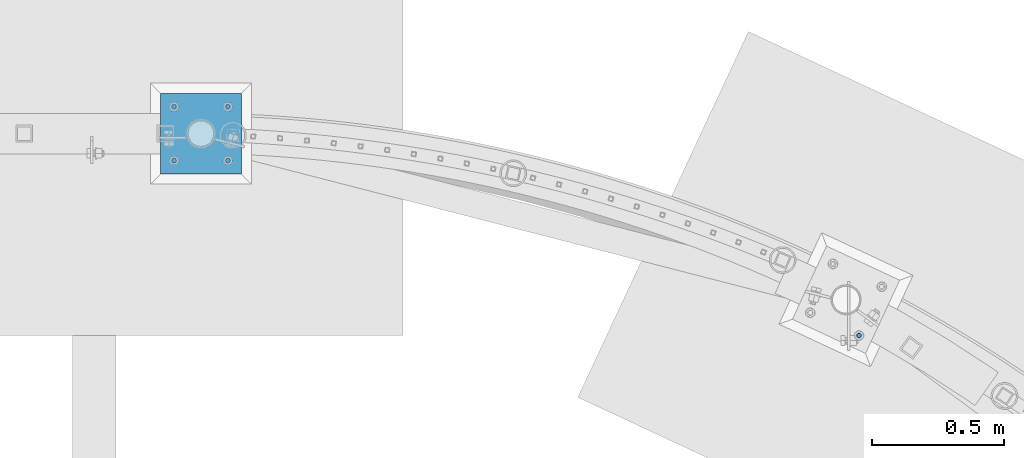
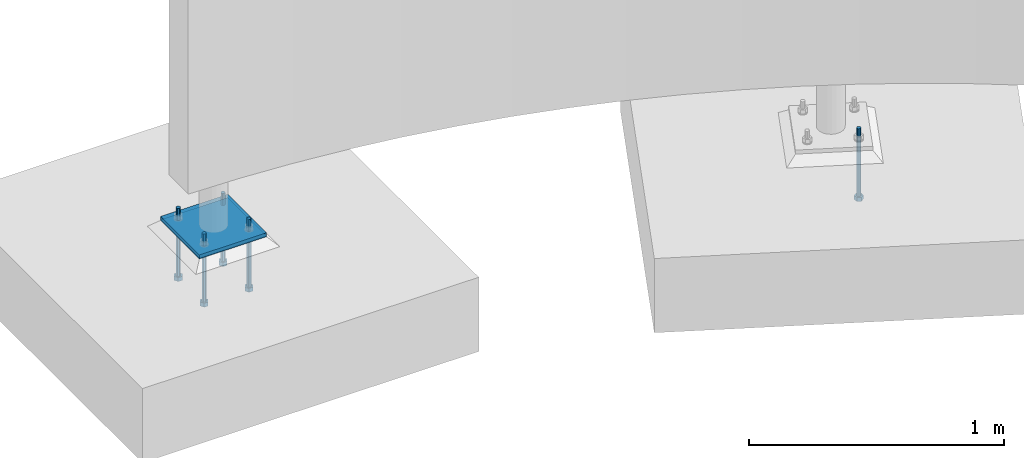
# One storey, part 449 of 975: 7 beams.
"""IFC2X3 building model written with IfcOpenShell, lengths in millimetres."""

import ifcopenshell
import ifcopenshell.guid

model = None  # the IFC model being written
_history = None  # IfcOwnerHistory: only IFC2X3 demands one
_inside = {}  # id of a spatial element -> (the spatial element, [elements in it])
_under = {}  # id of a project, library or spatial element -> (it, [spatial elements below it])
_declared = {}  # id of a project -> (the project, [libraries it declares])
_typed = {}  # id of a type object -> (the type object, [elements of that type])
_made_of = {}  # id of a material, layer set ... -> (it, [elements and type objects made of it])


def new_model(schema):
    """Start an empty IFC model of exactly this schema.

    Asked for "IFC4X3", IfcOpenShell would pick the latest addendum, in which some entities
    have other attributes; the version numbers below select the first issue.
    IFC2X3 requires an IfcOwnerHistory on every rooted entity: one is made here for all.
    """
    global model, _history
    if schema == "IFC4X3":
        model = ifcopenshell.file(schema_version=(4, 3, 0, 0))
    else:
        model = ifcopenshell.file(schema=schema)
    _inside.clear()
    _under.clear()
    _declared.clear()
    _typed.clear()
    _made_of.clear()
    _history = None
    if model.schema == "IFC2X3":
        org = make("IfcOrganization", Name="unknown")
        user = make(
            "IfcPersonAndOrganization",
            ThePerson=make("IfcPerson", FamilyName="unknown"),
            TheOrganization=org,
        )
        app = make(
            "IfcApplication",
            ApplicationDeveloper=org,
            Version="unknown",
            ApplicationFullName="unknown",
            ApplicationIdentifier="unknown",
        )
        _history = make(
            "IfcOwnerHistory",
            OwningUser=user,
            OwningApplication=app,
            ChangeAction="ADDED",
            CreationDate=0,
        )
    return model


def make(cls, **values):
    """One entity of the class cls with the attributes given. An attribute that is None is left unset."""
    return model.create_entity(
        cls, **{name: value for name, value in values.items() if value is not None}
    )


def rooted(cls, **values):
    """An entity with a GlobalId (a new one), such as an element, a storey or a relation."""
    return make(cls, GlobalId=ifcopenshell.guid.new(), OwnerHistory=_history, **values)


def si_unit(unit_type, name, prefix=None):
    """IfcSIUnit, for example si_unit("LENGTHUNIT", "METRE", prefix="MILLI")."""
    return make("IfcSIUnit", UnitType=unit_type, Prefix=prefix, Name=name)


def assignment(units):
    """IfcUnitAssignment: the units of a project."""
    return None if units is None else make("IfcUnitAssignment", Units=units)


def point(xyz):
    """IfcCartesianPoint."""
    return None if xyz is None else make("IfcCartesianPoint", Coordinates=xyz)


def direction(xyz):
    """IfcDirection."""
    return None if xyz is None else make("IfcDirection", DirectionRatios=xyz)


def frame(location, z_axis=None, x_axis=None):
    """IfcAxis2Placement3D, a coordinate frame: its origin and axes. An axis left out is left unset."""
    return make(
        "IfcAxis2Placement3D",
        Location=point(location),
        Axis=direction(z_axis),
        RefDirection=direction(x_axis),
    )


def origin_with_axes():
    """The frame at (0, 0, 0) with the z axis (0, 0, 1) and the x axis (1, 0, 0) written out."""
    return frame((0.0, 0.0, 0.0), z_axis=(0.0, 0.0, 1.0), x_axis=(1.0, 0.0, 0.0))


def place(relative_to, where):
    """IfcLocalPlacement: puts the frame where relative to a parent placement (None: the world)."""
    return make(
        "IfcLocalPlacement", PlacementRelTo=relative_to, RelativePlacement=where
    )


def context(
    kind, dimensions, precision=None, world=None, true_north=None, identifier=None
):
    """IfcGeometricRepresentationContext, for example the 3D "Model" context."""
    return make(
        "IfcGeometricRepresentationContext",
        ContextIdentifier=identifier,
        ContextType=kind,
        CoordinateSpaceDimension=dimensions,
        Precision=precision,
        WorldCoordinateSystem=world,
        TrueNorth=true_north,
    )


def subcontext(parent, identifier, kind, view, scale=None):
    """IfcGeometricRepresentationSubContext, for example "Body" below "Model"."""
    return make(
        "IfcGeometricRepresentationSubContext",
        ContextIdentifier=identifier,
        ContextType=kind,
        ParentContext=parent,
        TargetScale=scale,
        TargetView=view,
    )


def project(units=None, contexts=None):
    """IfcProject with its units and contexts."""
    return rooted(
        "IfcProject",
        Name="project",
        RepresentationContexts=contexts,
        UnitsInContext=assignment(units),
    )


def spatial(cls, under=None, at=None, **own):
    """A site, building, storey or space (cls), placed at a placement, below another one or the project."""
    s = rooted(cls, ObjectPlacement=at, **own)
    if under is not None:
        _under.setdefault(under.id(), (under, []))[1].append(s)
    return s


def faces_of(points, faces, orient=None, outer=None):
    """IfcFace entities. A face is a list of loops; a loop is a list of indices into points, from 0.

    orient and outer hold one flag for each loop. By default every Orientation is true, the
    first loop of a face is its IfcFaceOuterBound and the others are IfcFaceBound.
    """
    made = []
    for i, loops in enumerate(faces):
        bounds = []
        for j, loop in enumerate(loops):
            is_outer = j == 0 if outer is None else outer[i][j]
            bounds.append(
                make(
                    "IfcFaceOuterBound" if is_outer else "IfcFaceBound",
                    Bound=make("IfcPolyLoop", Polygon=[points[k] for k in loop]),
                    Orientation=True if orient is None else orient[i][j],
                )
            )
        made.append(make("IfcFace", Bounds=bounds))
    return made


def faceted_brep(points, faces, orient=None, outer=None, voids=None):
    """IfcFacetedBrep: a solid bounded by flat faces; with voids (closed shells), ...WithVoids."""
    shared = [point(p) for p in points]
    hull = make("IfcClosedShell", CfsFaces=faces_of(shared, faces, orient, outer))
    if voids is None:
        return make("IfcFacetedBrep", Outer=hull)
    return make(
        "IfcFacetedBrepWithVoids",
        Outer=hull,
        Voids=[
            make(cls, CfsFaces=faces_of(shared, fs, o, b)) for cls, fs, o, b in voids
        ],
    )


def shape(context_of_items, identifier, shape_type, items):
    """IfcShapeRepresentation: the items that make up one representation, for example the "Body"."""
    return make(
        "IfcShapeRepresentation",
        ContextOfItems=context_of_items,
        RepresentationIdentifier=identifier,
        RepresentationType=shape_type,
        Items=items,
    )


def material(Name=None, Category=None):
    """IfcMaterial."""
    return make("IfcMaterial", Name=Name, Category=Category)


def made_of(thing, what):
    """Note that an element or type object is made of a material, layer set ...; save() writes the relation."""
    if what is not None:
        _made_of.setdefault(what.id(), (what, []))[1].append(thing)
    return thing


def type_object(cls, material=None, **own):
    """A type object (cls), such as IfcWallType, which elements share."""
    return made_of(rooted(cls, **own), material)


def element(
    cls,
    number,
    at=None,
    inside=None,
    cuts=None,
    type_object=None,
    material=None,
    context=None,
    identifier="Body",
    shape_type=None,
    held_by="IfcProductDefinitionShape",
    body=None,
    shapes=None,
    **own,
):
    """One element of the class cls, such as IfcWall. Its Tag is "e" and its number.

    at: its placement. inside: the storey or other place that contains it. cuts: it is an
    opening in that element (IfcRelVoidsElement). A single representation is given by context,
    identifier, shape_type and body (its items); several are given by shapes. held_by: the class
    of the entity that holds the representations. save() writes the other relations.
    """
    e = rooted(cls, Tag="e%d" % number, ObjectPlacement=at, **own)
    if body is not None:
        shapes = [shape(context, identifier, shape_type, body)]
    if shapes is not None:
        e.Representation = make(held_by, Representations=shapes)
    if inside is not None:
        _inside.setdefault(inside.id(), (inside, []))[1].append(e)
    if cuts is not None:
        rooted(
            "IfcRelVoidsElement", RelatingBuildingElement=cuts, RelatedOpeningElement=e
        )
    if type_object is not None:
        _typed.setdefault(type_object.id(), (type_object, []))[1].append(e)
    return made_of(e, material)


def aggregate(whole, parts):
    """IfcRelAggregates: a whole, such as a stair, and the parts it consists of."""
    return rooted("IfcRelAggregates", RelatingObject=whole, RelatedObjects=parts)


def save(model, path):
    """Write the relations noted so far, then the file.

    IfcRelAggregates (storeys below a building ...), IfcRelContainedInSpatialStructure (elements
    in a storey), IfcRelDefinesByType, IfcRelAssociatesMaterial and IfcRelDeclares: one each for
    every whole, place, type object, material and project.
    """
    for whole, parts in _under.values():
        aggregate(whole, parts)
    for where, things in _inside.values():
        rooted(
            "IfcRelContainedInSpatialStructure",
            RelatedElements=things,
            RelatingStructure=where,
        )
    for kind, things in _typed.values():
        rooted("IfcRelDefinesByType", RelatedObjects=things, RelatingType=kind)
    for what, things in _made_of.values():
        rooted("IfcRelAssociatesMaterial", RelatedObjects=things, RelatingMaterial=what)
    for by, libraries in _declared.values():
        rooted("IfcRelDeclares", RelatingContext=by, RelatedDefinitions=libraries)
    model.write(path)


model = new_model("IFC2X3")

# Units and contexts
model_context = context("Model", 3, precision=1e-05, world=origin_with_axes())
body_context = subcontext(model_context, "Body", "Model", "MODEL_VIEW")
ifc_project = project(units=[si_unit("LENGTHUNIT", "METRE", prefix="MILLI"), si_unit("AREAUNIT", "SQUARE_METRE"), si_unit("VOLUMEUNIT", "CUBIC_METRE"), si_unit("MASSUNIT", "GRAM", prefix="KILO"), si_unit("TIMEUNIT", "SECOND"), si_unit("PLANEANGLEUNIT", "RADIAN"), si_unit("SOLIDANGLEUNIT", "STERADIAN"), si_unit("THERMODYNAMICTEMPERATUREUNIT", "DEGREE_CELSIUS"), si_unit("LUMINOUSINTENSITYUNIT", "LUMEN")], contexts=[model_context])

# Site, building, storey
site_placement = place(None, origin_with_axes())
site = spatial("IfcSite", under=ifc_project, at=site_placement, CompositionType="ELEMENT")
building_placement = place(site_placement, origin_with_axes())
building = spatial("IfcBuilding", under=site, at=building_placement, Name="Undefined", CompositionType="ELEMENT")
storey_placement = place(building_placement, origin_with_axes())
storey = spatial("IfcBuildingStorey", under=building, at=storey_placement, Name="Undefined", CompositionType="ELEMENT", Elevation=0.0)

# Beams
ifc_material_1 = material(Name="STEEL/A36")
beam_type_1 = type_object("IfcBeamType", PredefinedType="NOTDEFINED")
beam_1_placement = place(storey_placement, frame((16424.275, 29810.075, -257.175), z_axis=(-0.999999999999998, 6.90000001668524e-08, 0.0), x_axis=(0.0, 1.0, 0.0)))
element("IfcBeam", 1, at=beam_1_placement, inside=storey, type_object=beam_type_1, material=ifc_material_1, Name="PLATE", context=body_context, shape_type="Brep", body=[
    faceted_brep([(0.0, 9.52499999999964, -152.4), (0.0, 9.52499999999964, 152.4), (304.799999999152, 9.52499999999964, 152.4), (304.799999999152, 9.52499999999964, -152.4), (0.0, -9.52499999999964, 152.4), (304.799999999152, -9.52499999999964, 152.4), (0.0, -9.52499999999964, -152.4), (304.799999999152, -9.52499999999964, -152.4)], [[[0, 1, 2, 3]], [[1, 4, 5, 2]], [[4, 6, 7, 5]], [[6, 0, 3, 7]], [[5, 7, 3, 2]], [[6, 4, 1, 0]]]),
])
ifc_material_2 = material(Name="STEEL/F1554-36")
beam_type_2 = type_object("IfcBeamType", PredefinedType="NOTDEFINED")
beam_2_placement = place(storey_placement, frame((18908.6428556432, 29200.3659553737, -304.799999999999), z_axis=(0.422618261967726, 0.906307786930786, 0.0), x_axis=(0.0, 0.0, -1.0)))
element("IfcBeam", 2, at=beam_2_placement, inside=storey, type_object=beam_type_2, material=ifc_material_2, Name="HEADED_ANCHOR_BOLT", context=body_context, shape_type="Brep", body=[
    faceted_brep([(209.543749999999, -9.13000011446275, 15.8100004196049), (209.543749999999, -18.2600002288382, 4.72937244921923e-11), (228.593749999998, -18.2600002288382, 4.72937244921923e-11), (228.593749999998, -9.13000011446275, 15.8100004196049), (209.543749999999, 9.13000011438271, 15.8100004195576), (228.593749999998, 9.13000011438271, 15.8100004195576), (209.543749999999, 18.2600002288382, -4.72937244921923e-11), (228.593749999998, 18.2600002288382, -4.72937244921923e-11), (209.543749999999, 9.13000011446275, -15.8100004196049), (228.593749999998, 9.13000011446275, -15.8100004196049), (209.543749999999, -9.13000011438271, -15.8100004195576), (228.593749999998, -9.13000011438271, -15.8100004195576), (209.543749999999, -4.4776800552936, 9.29799844178979), (209.543749999999, -8.068500660469, 6.43441456491473), (209.543749999999, -10.0612557561763, 2.2964159705416), (209.543749999999, -10.0612557561617, -2.29641597048976), (209.543749999999, -8.0685006604399, -6.4344145648729), (209.543749999999, -4.47768005524995, -9.29799844176705), (209.543749999999, 2.91038304567337e-11, -10.3199996948015), (209.543749999999, 4.4776800552936, -9.29799844178979), (209.543749999999, 8.068500660469, -6.43441456491473), (209.543749999999, 10.0612557561763, -2.2964159705416), (209.543749999999, 10.0612557561617, 2.29641597048976), (209.543749999999, 8.0685006604399, 6.4344145648729), (209.543749999999, 4.47768005524995, 9.29799844176705), (209.543749999999, -2.91038304567337e-11, 10.3199996948015), (228.593749999998, -2.91038304567337e-11, 10.3199996948015), (228.593749999998, -4.4776800552936, 9.29799844178979), (228.593749999998, -8.068500660469, 6.43441456491473), (228.593749999998, -10.0612557561763, 2.2964159705416), (228.593749999998, -10.0612557561617, -2.29641597048976), (228.593749999998, -8.0685006604399, -6.4344145648729), (228.593749999998, -4.47768005524995, -9.29799844176705), (228.593749999998, 2.91038304567337e-11, -10.3199996948015), (228.593749999998, 4.4776800552936, -9.29799844178979), (228.593749999998, 8.068500660469, -6.43441456491473), (228.593749999998, 10.0612557561763, -2.2964159705416), (228.593749999998, 10.0612557561617, 2.29641597048976), (228.593749999998, 8.0685006604399, 6.4344145648729), (228.593749999998, 4.47768005524995, 9.29799844176705), (0.0, -6.73519209080223, 6.73519209080186), (0.0, -9.52499999999964, 0.0), (228.6, -9.52500000000146, 0.0), (228.6, -6.73519209080405, 6.73519209080223), (-9.87109982941227e-13, -1.20792265079217e-13, 9.52499961853027), (228.6, 0.0, 9.52499999999964), (0.0, 6.73519209080223, 6.73519209080186), (228.6, 6.73519209080405, 6.73519209080223), (0.0, 9.52499999999964, 0.0), (228.6, 9.52500000000146, 0.0), (0.0, 6.73519209080223, -6.73519209080186), (228.6, 6.73519209080405, -6.73519209080223), (2.95075507493764e-12, -1.20792265079217e-13, -9.52499961853027), (228.6, 0.0, -9.52499999999964), (-114.297914995421, -6.36396103067818, 6.36396103068091), (-114.297914995421, -2.18278728425503e-11, 8.99999999997999), (-114.297914995421, 6.36396103064908, 6.36396103064817), (-114.297914995421, 8.99999999997817, -2.27373675443232e-11), (-114.297914995421, 6.36396103067818, -6.36396103068091), (-114.297914995421, 2.18278728425503e-11, -8.99999999997999), (-114.297914995421, -6.36396103064908, -6.36396103064817), (-114.297914995421, -8.99999999997817, 2.27373675443232e-11), (0.0149743263646087, 6.36396103067818, -6.36396103067909), (0.0149743263646087, 0.0, -9.0), (0.0149743263646087, -6.36396103067818, -6.36396103067909), (0.0149743263987148, -8.9999995411581, -1.00796984270346e-06), (0.0149743263646087, -6.36396103067818, 6.36396103067909), (0.0149743263646087, 0.0, 9.0), (0.0149743263646087, 6.36396103067818, 6.36396103067909), (0.0149743263987148, 9.0000004588419, -1.00796984270346e-06), (0.0, -6.73519209080223, -6.73519209080186), (228.6, -6.73519209080405, -6.73519209080223)], [[[0, 1, 2, 3]], [[4, 0, 3, 5]], [[6, 4, 5, 7]], [[8, 6, 7, 9]], [[10, 8, 9, 11]], [[0, 4, 6, 8, 10, 1], [12, 13, 14, 15, 16, 17, 18, 19, 20, 21, 22, 23, 24, 25]], [[12, 25, 26, 27]], [[13, 12, 27, 28]], [[14, 13, 28, 29]], [[15, 14, 29, 30]], [[16, 15, 30, 31]], [[17, 16, 31, 32]], [[18, 17, 32, 33]], [[19, 18, 33, 34]], [[20, 19, 34, 35]], [[21, 20, 35, 36]], [[22, 21, 36, 37]], [[23, 22, 37, 38]], [[24, 23, 38, 39]], [[25, 24, 39, 26]], [[9, 7, 5, 3, 2, 11], [38, 37, 36, 35, 34, 33, 32, 31, 30, 29, 28, 27, 26, 39]], [[1, 10, 11, 2]], [[40, 41, 42, 43]], [[44, 40, 43, 45]], [[46, 44, 45, 47]], [[48, 46, 47, 49]], [[50, 48, 49, 51]], [[52, 50, 51, 53]], [[54, 55, 56, 57, 58, 59, 60, 61]], [[59, 58, 62, 63]], [[60, 59, 63, 64]], [[61, 60, 64, 65]], [[54, 61, 65, 66]], [[55, 54, 66, 67]], [[56, 55, 67, 68]], [[57, 56, 68, 69]], [[58, 57, 69, 62]], [[40, 44, 46, 48, 50, 52, 70, 41], [68, 67, 66, 65, 64, 63, 62, 69]], [[41, 70, 71, 42]], [[53, 51, 49, 47, 45, 43, 42, 71]], [[70, 52, 53, 71]]]),
])
beam_3_placement = place(storey_placement, frame((16525.8749984741, 30064.0749969482, -304.79470833123), z_axis=(0.0, 1.0, 0.0), x_axis=(0.0, 0.0, -1.0)))
element("IfcBeam", 3, at=beam_3_placement, inside=storey, type_object=beam_type_2, material=ifc_material_2, Name="HEADED_ANCHOR_BOLT", context=body_context, shape_type="Brep", body=[
    faceted_brep([(210.349041668767, -9.13000011445183, 15.8100004196131), (210.349041668767, -18.2600002288636, 2.5465851649642e-11), (229.399041668767, -18.2600002288636, 2.5465851649642e-11), (229.399041668767, -9.13000011445183, 15.8100004196131), (210.349041668767, 9.13000011440818, 15.8100004195894), (229.399041668767, 9.13000011440818, 15.8100004195894), (210.349041668767, 18.26000022886, -2.18278728425503e-11), (229.399041668767, 18.26000022886, -2.18278728425503e-11), (210.349041668767, 9.13000011444819, -15.8100004196076), (229.399041668767, 9.13000011444819, -15.8100004196076), (210.349041668767, -9.13000011441545, -15.8100004195876), (229.399041668767, -9.13000011441545, -15.8100004195876), (210.349041668767, -4.47768005528997, 9.29799844179615), (210.349041668767, -8.06850066047264, 6.43441456491382), (210.349041668767, -10.0612557561872, 2.2964159705316), (210.349041668767, -10.0612557561799, -2.29641597050431), (210.349041668767, -8.06850066045808, -6.43441456488472), (210.349041668767, -4.47768005526814, -9.2979984417816), (210.349041668767, 1.09139364212751e-11, -10.3199996948097), (210.349041668767, 4.47768005528997, -9.29799844179433), (210.349041668767, 8.06850066047264, -6.43441456491018), (210.349041668767, 10.0612557561799, -2.29641597052978), (210.349041668767, 10.0612557561763, 2.29641597051159), (210.349041668767, 8.06850066045808, 6.43441456489199), (210.349041668767, 4.47768005526086, 9.29799844178342), (210.349041668767, -1.09139364212751e-11, 10.3199996948151), (229.399041668767, -1.09139364212751e-11, 10.3199996948151), (229.399041668767, -4.47768005528997, 9.29799844179615), (229.399041668767, -8.06850066047264, 6.43441456491382), (229.399041668767, -10.0612557561872, 2.2964159705316), (229.399041668767, -10.0612557561799, -2.29641597050431), (229.399041668767, -8.06850066045808, -6.43441456488472), (229.399041668767, -4.47768005526814, -9.2979984417816), (229.399041668767, 1.09139364212751e-11, -10.3199996948097), (229.399041668767, 4.47768005528997, -9.29799844179433), (229.399041668767, 8.06850066047264, -6.43441456491018), (229.399041668767, 10.0612557561799, -2.29641597052978), (229.399041668767, 10.0612557561763, 2.29641597051159), (229.399041668767, 8.06850066045808, 6.43441456489199), (229.399041668767, 4.47768005526086, 9.29799844178342), (0.0, -6.73519209080223, 6.73519209080186), (0.0, -9.52499999999964, 0.0), (228.605291668766, -9.52499999999054, 1.45519152283669e-11), (228.605291668766, -6.73519209080405, 6.73519209080405), (-9.87109982941227e-13, -1.20792265079217e-13, 9.52499961853027), (228.605291668766, -1.09139364212751e-11, 9.52499999999054), (0.0, 6.73519209080223, 6.73519209080186), (228.605291668766, 6.73519209078586, 6.73519209078768), (0.0, 9.52499999999964, 0.0), (228.605291668766, 9.52499999999054, -9.09494701772928e-12), (0.0, 6.73519209080223, -6.73519209080186), (228.605291668766, 6.73519209080041, -6.73519209080223), (2.95075507493764e-12, -1.20792265079217e-13, -9.52499961853027), (228.605291668766, 1.09139364212751e-11, -9.52499999998508), (-114.294672089865, -6.36396103028892, 6.36396103068546), (-114.29460082623, -1.09139364212751e-11, 8.99999999999091), (-114.294529562594, 6.36396103026709, 6.36396103066909), (-114.29450004423, 8.99999999943611, -9.09494701772928e-12), (-114.294529562594, 6.36396103028528, -6.36396103067455), (-114.29460082623, 1.09139364212751e-11, -8.99999999998909), (-114.294672089865, -6.36396103027437, -6.36396103066363), (-114.29470160823, -8.99999999943611, 1.45519152283669e-11), (0.00536293275933986, 6.36268110000674, -6.36396103067818), (0.00529166912366463, -0.00127993026762852, -8.99999999998545), (0.00522040548793257, -6.36524096055291, -6.36396103066181), (0.00519088712354687, -9.00127992971102, 1.45519152283669e-11), (0.00522040548793257, -6.36524096056746, 6.36396103068182), (0.00529166912366463, -0.00127993029309437, 8.99999999999454), (0.00536293275933986, 6.36268109998855, 6.36396103066545), (0.00539245112372555, 8.99872006915029, -9.09494701772928e-12), (0.0, -6.73519209080223, -6.73519209080186), (228.605291668766, -6.73519209078586, -6.7351920907804)], [[[0, 1, 2, 3]], [[4, 0, 3, 5]], [[6, 4, 5, 7]], [[8, 6, 7, 9]], [[10, 8, 9, 11]], [[0, 4, 6, 8, 10, 1], [12, 13, 14, 15, 16, 17, 18, 19, 20, 21, 22, 23, 24, 25]], [[12, 25, 26, 27]], [[13, 12, 27, 28]], [[14, 13, 28, 29]], [[15, 14, 29, 30]], [[16, 15, 30, 31]], [[17, 16, 31, 32]], [[18, 17, 32, 33]], [[19, 18, 33, 34]], [[20, 19, 34, 35]], [[21, 20, 35, 36]], [[22, 21, 36, 37]], [[23, 22, 37, 38]], [[24, 23, 38, 39]], [[25, 24, 39, 26]], [[9, 7, 5, 3, 2, 11], [38, 37, 36, 35, 34, 33, 32, 31, 30, 29, 28, 27, 26, 39]], [[1, 10, 11, 2]], [[40, 41, 42, 43]], [[44, 40, 43, 45]], [[46, 44, 45, 47]], [[48, 46, 47, 49]], [[50, 48, 49, 51]], [[52, 50, 51, 53]], [[54, 55, 56, 57, 58, 59, 60, 61]], [[59, 58, 62, 63]], [[60, 59, 63, 64]], [[61, 60, 64, 65]], [[54, 61, 65, 66]], [[55, 54, 66, 67]], [[56, 55, 67, 68]], [[57, 56, 68, 69]], [[58, 57, 69, 62]], [[40, 44, 46, 48, 50, 52, 70, 41], [68, 67, 66, 65, 64, 63, 62, 69]], [[41, 70, 71, 42]], [[53, 51, 49, 47, 45, 43, 42, 71]], [[70, 52, 53, 71]]]),
])
beam_4_placement = place(storey_placement, frame((16322.6750015259, 30064.0749969482, -304.79470833123), z_axis=(0.0, -1.0, 0.0), x_axis=(0.0, 0.0, -1.0)))
element("IfcBeam", 4, at=beam_4_placement, inside=storey, type_object=beam_type_2, material=ifc_material_2, Name="HEADED_ANCHOR_BOLT", context=body_context, shape_type="Brep", body=[
    faceted_brep([(210.349041668767, -9.13000011445183, 15.8100004196131), (210.349041668767, -18.2600002288636, 2.5465851649642e-11), (229.399041668767, -18.2600002288636, 2.5465851649642e-11), (229.399041668767, -9.13000011445183, 15.8100004196131), (210.349041668767, 9.13000011440818, 15.8100004195894), (229.399041668767, 9.13000011440818, 15.8100004195894), (210.349041668767, 18.26000022886, -2.18278728425503e-11), (229.399041668767, 18.26000022886, -2.18278728425503e-11), (210.349041668767, 9.13000011444819, -15.8100004196076), (229.399041668767, 9.13000011444819, -15.8100004196076), (210.349041668767, -9.13000011441545, -15.8100004195876), (229.399041668767, -9.13000011441545, -15.8100004195876), (210.349041668767, -4.47768005528997, 9.29799844179615), (210.349041668767, -8.06850066047264, 6.43441456491382), (210.349041668767, -10.0612557561872, 2.2964159705316), (210.349041668767, -10.0612557561799, -2.29641597050431), (210.349041668767, -8.06850066045808, -6.43441456488472), (210.349041668767, -4.47768005526814, -9.2979984417816), (210.349041668767, 1.09139364212751e-11, -10.3199996948097), (210.349041668767, 4.47768005528997, -9.29799844179433), (210.349041668767, 8.06850066047264, -6.43441456491018), (210.349041668767, 10.0612557561799, -2.29641597052978), (210.349041668767, 10.0612557561763, 2.29641597051159), (210.349041668767, 8.06850066045808, 6.43441456489199), (210.349041668767, 4.47768005526086, 9.29799844178342), (210.349041668767, -1.09139364212751e-11, 10.3199996948151), (229.399041668767, -1.09139364212751e-11, 10.3199996948151), (229.399041668767, -4.47768005528997, 9.29799844179615), (229.399041668767, -8.06850066047264, 6.43441456491382), (229.399041668767, -10.0612557561872, 2.2964159705316), (229.399041668767, -10.0612557561799, -2.29641597050431), (229.399041668767, -8.06850066045808, -6.43441456488472), (229.399041668767, -4.47768005526814, -9.2979984417816), (229.399041668767, 1.09139364212751e-11, -10.3199996948097), (229.399041668767, 4.47768005528997, -9.29799844179433), (229.399041668767, 8.06850066047264, -6.43441456491018), (229.399041668767, 10.0612557561799, -2.29641597052978), (229.399041668767, 10.0612557561763, 2.29641597051159), (229.399041668767, 8.06850066045808, 6.43441456489199), (229.399041668767, 4.47768005526086, 9.29799844178342), (0.0, -6.73519209080223, 6.73519209080186), (0.0, -9.52499999999964, 0.0), (228.605291668766, -9.52499999999054, 1.45519152283669e-11), (228.605291668766, -6.73519209080405, 6.73519209080405), (-9.87109982941227e-13, -1.20792265079217e-13, 9.52499961853027), (228.605291668766, -1.09139364212751e-11, 9.52499999999054), (0.0, 6.73519209080223, 6.73519209080186), (228.605291668766, 6.73519209078586, 6.73519209078768), (0.0, 9.52499999999964, 0.0), (228.605291668766, 9.52499999999054, -9.09494701772928e-12), (0.0, 6.73519209080223, -6.73519209080186), (228.605291668766, 6.73519209080041, -6.73519209080223), (2.95075507493764e-12, -1.20792265079217e-13, -9.52499961853027), (228.605291668766, 1.09139364212751e-11, -9.52499999998508), (-114.294672089865, -6.36396103028892, 6.36396103068546), (-114.29460082623, -1.09139364212751e-11, 8.99999999999091), (-114.294529562594, 6.36396103026709, 6.36396103066909), (-114.29450004423, 8.99999999943611, -9.09494701772928e-12), (-114.294529562594, 6.36396103028528, -6.36396103067455), (-114.29460082623, 1.09139364212751e-11, -8.99999999998909), (-114.294672089865, -6.36396103027437, -6.36396103066363), (-114.29470160823, -8.99999999943611, 1.45519152283669e-11), (0.00536293275933986, 6.36268110000674, -6.36396103067818), (0.00529166912366463, -0.00127993026762852, -8.99999999998545), (0.00522040548793257, -6.36524096055291, -6.36396103066181), (0.00519088712354687, -9.00127992971102, 1.45519152283669e-11), (0.00522040548793257, -6.36524096056746, 6.36396103068182), (0.00529166912366463, -0.00127993029309437, 8.99999999999454), (0.00536293275933986, 6.36268109998855, 6.36396103066545), (0.00539245112372555, 8.99872006915029, -9.09494701772928e-12), (0.0, -6.73519209080223, -6.73519209080186), (228.605291668766, -6.73519209078586, -6.7351920907804)], [[[0, 1, 2, 3]], [[4, 0, 3, 5]], [[6, 4, 5, 7]], [[8, 6, 7, 9]], [[10, 8, 9, 11]], [[0, 4, 6, 8, 10, 1], [12, 13, 14, 15, 16, 17, 18, 19, 20, 21, 22, 23, 24, 25]], [[12, 25, 26, 27]], [[13, 12, 27, 28]], [[14, 13, 28, 29]], [[15, 14, 29, 30]], [[16, 15, 30, 31]], [[17, 16, 31, 32]], [[18, 17, 32, 33]], [[19, 18, 33, 34]], [[20, 19, 34, 35]], [[21, 20, 35, 36]], [[22, 21, 36, 37]], [[23, 22, 37, 38]], [[24, 23, 38, 39]], [[25, 24, 39, 26]], [[9, 7, 5, 3, 2, 11], [38, 37, 36, 35, 34, 33, 32, 31, 30, 29, 28, 27, 26, 39]], [[1, 10, 11, 2]], [[40, 41, 42, 43]], [[44, 40, 43, 45]], [[46, 44, 45, 47]], [[48, 46, 47, 49]], [[50, 48, 49, 51]], [[52, 50, 51, 53]], [[54, 55, 56, 57, 58, 59, 60, 61]], [[59, 58, 62, 63]], [[60, 59, 63, 64]], [[61, 60, 64, 65]], [[54, 61, 65, 66]], [[55, 54, 66, 67]], [[56, 55, 67, 68]], [[57, 56, 68, 69]], [[58, 57, 69, 62]], [[40, 44, 46, 48, 50, 52, 70, 41], [68, 67, 66, 65, 64, 63, 62, 69]], [[41, 70, 71, 42]], [[53, 51, 49, 47, 45, 43, 42, 71]], [[70, 52, 53, 71]]]),
])
beam_5_placement = place(storey_placement, frame((16322.6750015259, 29860.875, -304.79470833123), z_axis=(0.0, -1.0, 0.0), x_axis=(0.0, 0.0, -1.0)))
element("IfcBeam", 5, at=beam_5_placement, inside=storey, type_object=beam_type_2, material=ifc_material_2, Name="HEADED_ANCHOR_BOLT", context=body_context, shape_type="Brep", body=[
    faceted_brep([(210.349041668767, -9.13000011445183, 15.8100004196131), (210.349041668767, -18.2600002288636, 2.5465851649642e-11), (229.399041668767, -18.2600002288636, 2.5465851649642e-11), (229.399041668767, -9.13000011445183, 15.8100004196131), (210.349041668767, 9.13000011440818, 15.8100004195894), (229.399041668767, 9.13000011440818, 15.8100004195894), (210.349041668767, 18.26000022886, -2.18278728425503e-11), (229.399041668767, 18.26000022886, -2.18278728425503e-11), (210.349041668767, 9.13000011444819, -15.8100004196076), (229.399041668767, 9.13000011444819, -15.8100004196076), (210.349041668767, -9.13000011441545, -15.8100004195876), (229.399041668767, -9.13000011441545, -15.8100004195876), (210.349041668767, -4.47768005528997, 9.29799844179615), (210.349041668767, -8.06850066047264, 6.43441456491382), (210.349041668767, -10.0612557561872, 2.2964159705316), (210.349041668767, -10.0612557561799, -2.29641597050431), (210.349041668767, -8.06850066045808, -6.43441456488472), (210.349041668767, -4.47768005526814, -9.2979984417816), (210.349041668767, 1.09139364212751e-11, -10.3199996948097), (210.349041668767, 4.47768005528997, -9.29799844179433), (210.349041668767, 8.06850066047264, -6.43441456491018), (210.349041668767, 10.0612557561799, -2.29641597052978), (210.349041668767, 10.0612557561763, 2.29641597051159), (210.349041668767, 8.06850066045808, 6.43441456489199), (210.349041668767, 4.47768005526086, 9.29799844178342), (210.349041668767, -1.09139364212751e-11, 10.3199996948151), (229.399041668767, -1.09139364212751e-11, 10.3199996948151), (229.399041668767, -4.47768005528997, 9.29799844179615), (229.399041668767, -8.06850066047264, 6.43441456491382), (229.399041668767, -10.0612557561872, 2.2964159705316), (229.399041668767, -10.0612557561799, -2.29641597050431), (229.399041668767, -8.06850066045808, -6.43441456488472), (229.399041668767, -4.47768005526814, -9.2979984417816), (229.399041668767, 1.09139364212751e-11, -10.3199996948097), (229.399041668767, 4.47768005528997, -9.29799844179433), (229.399041668767, 8.06850066047264, -6.43441456491018), (229.399041668767, 10.0612557561799, -2.29641597052978), (229.399041668767, 10.0612557561763, 2.29641597051159), (229.399041668767, 8.06850066045808, 6.43441456489199), (229.399041668767, 4.47768005526086, 9.29799844178342), (0.0, -6.73519209080223, 6.73519209080186), (0.0, -9.52499999999964, 0.0), (228.605291668766, -9.52499999999054, 1.45519152283669e-11), (228.605291668766, -6.73519209080405, 6.73519209080405), (-9.87109982941227e-13, -1.20792265079217e-13, 9.52499961853027), (228.605291668766, -1.09139364212751e-11, 9.52499999999054), (0.0, 6.73519209080223, 6.73519209080186), (228.605291668766, 6.73519209078586, 6.73519209078768), (0.0, 9.52499999999964, 0.0), (228.605291668766, 9.52499999999054, -9.09494701772928e-12), (0.0, 6.73519209080223, -6.73519209080186), (228.605291668766, 6.73519209080041, -6.73519209080223), (2.95075507493764e-12, -1.20792265079217e-13, -9.52499961853027), (228.605291668766, 1.09139364212751e-11, -9.52499999998508), (-114.294672089865, -6.36396103028892, 6.36396103068546), (-114.29460082623, -1.09139364212751e-11, 8.99999999999091), (-114.294529562594, 6.36396103026709, 6.36396103066909), (-114.29450004423, 8.99999999943611, -9.09494701772928e-12), (-114.294529562594, 6.36396103028528, -6.36396103067455), (-114.29460082623, 1.09139364212751e-11, -8.99999999998909), (-114.294672089865, -6.36396103027437, -6.36396103066363), (-114.29470160823, -8.99999999943611, 1.45519152283669e-11), (0.00536293275933986, 6.36268110000674, -6.36396103067818), (0.00529166912366463, -0.00127993026762852, -8.99999999998545), (0.00522040548793257, -6.36524096055291, -6.36396103066181), (0.00519088712354687, -9.00127992971102, 1.45519152283669e-11), (0.00522040548793257, -6.36524096056746, 6.36396103068182), (0.00529166912366463, -0.00127993029309437, 8.99999999999454), (0.00536293275933986, 6.36268109998855, 6.36396103066545), (0.00539245112372555, 8.99872006915029, -9.09494701772928e-12), (0.0, -6.73519209080223, -6.73519209080186), (228.605291668766, -6.73519209078586, -6.7351920907804)], [[[0, 1, 2, 3]], [[4, 0, 3, 5]], [[6, 4, 5, 7]], [[8, 6, 7, 9]], [[10, 8, 9, 11]], [[0, 4, 6, 8, 10, 1], [12, 13, 14, 15, 16, 17, 18, 19, 20, 21, 22, 23, 24, 25]], [[12, 25, 26, 27]], [[13, 12, 27, 28]], [[14, 13, 28, 29]], [[15, 14, 29, 30]], [[16, 15, 30, 31]], [[17, 16, 31, 32]], [[18, 17, 32, 33]], [[19, 18, 33, 34]], [[20, 19, 34, 35]], [[21, 20, 35, 36]], [[22, 21, 36, 37]], [[23, 22, 37, 38]], [[24, 23, 38, 39]], [[25, 24, 39, 26]], [[9, 7, 5, 3, 2, 11], [38, 37, 36, 35, 34, 33, 32, 31, 30, 29, 28, 27, 26, 39]], [[1, 10, 11, 2]], [[40, 41, 42, 43]], [[44, 40, 43, 45]], [[46, 44, 45, 47]], [[48, 46, 47, 49]], [[50, 48, 49, 51]], [[52, 50, 51, 53]], [[54, 55, 56, 57, 58, 59, 60, 61]], [[59, 58, 62, 63]], [[60, 59, 63, 64]], [[61, 60, 64, 65]], [[54, 61, 65, 66]], [[55, 54, 66, 67]], [[56, 55, 67, 68]], [[57, 56, 68, 69]], [[58, 57, 69, 62]], [[40, 44, 46, 48, 50, 52, 70, 41], [68, 67, 66, 65, 64, 63, 62, 69]], [[41, 70, 71, 42]], [[53, 51, 49, 47, 45, 43, 42, 71]], [[70, 52, 53, 71]]]),
])
beam_6_placement = place(storey_placement, frame((16525.8749984741, 29860.875, -304.79470833123), z_axis=(0.0, 1.0, 0.0), x_axis=(0.0, 0.0, -1.0)))
element("IfcBeam", 6, at=beam_6_placement, inside=storey, type_object=beam_type_2, material=ifc_material_2, Name="HEADED_ANCHOR_BOLT", context=body_context, shape_type="Brep", body=[
    faceted_brep([(210.349041668767, -9.13000011445183, 15.8100004196131), (210.349041668767, -18.2600002288636, 2.5465851649642e-11), (229.399041668767, -18.2600002288636, 2.5465851649642e-11), (229.399041668767, -9.13000011445183, 15.8100004196131), (210.349041668767, 9.13000011440818, 15.8100004195894), (229.399041668767, 9.13000011440818, 15.8100004195894), (210.349041668767, 18.26000022886, -2.18278728425503e-11), (229.399041668767, 18.26000022886, -2.18278728425503e-11), (210.349041668767, 9.13000011444819, -15.8100004196076), (229.399041668767, 9.13000011444819, -15.8100004196076), (210.349041668767, -9.13000011441545, -15.8100004195876), (229.399041668767, -9.13000011441545, -15.8100004195876), (210.349041668767, -4.47768005528997, 9.29799844179615), (210.349041668767, -8.06850066047264, 6.43441456491382), (210.349041668767, -10.0612557561872, 2.2964159705316), (210.349041668767, -10.0612557561799, -2.29641597050431), (210.349041668767, -8.06850066045808, -6.43441456488472), (210.349041668767, -4.47768005526814, -9.2979984417816), (210.349041668767, 1.09139364212751e-11, -10.3199996948097), (210.349041668767, 4.47768005528997, -9.29799844179433), (210.349041668767, 8.06850066047264, -6.43441456491018), (210.349041668767, 10.0612557561799, -2.29641597052978), (210.349041668767, 10.0612557561763, 2.29641597051159), (210.349041668767, 8.06850066045808, 6.43441456489199), (210.349041668767, 4.47768005526086, 9.29799844178342), (210.349041668767, -1.09139364212751e-11, 10.3199996948151), (229.399041668767, -1.09139364212751e-11, 10.3199996948151), (229.399041668767, -4.47768005528997, 9.29799844179615), (229.399041668767, -8.06850066047264, 6.43441456491382), (229.399041668767, -10.0612557561872, 2.2964159705316), (229.399041668767, -10.0612557561799, -2.29641597050431), (229.399041668767, -8.06850066045808, -6.43441456488472), (229.399041668767, -4.47768005526814, -9.2979984417816), (229.399041668767, 1.09139364212751e-11, -10.3199996948097), (229.399041668767, 4.47768005528997, -9.29799844179433), (229.399041668767, 8.06850066047264, -6.43441456491018), (229.399041668767, 10.0612557561799, -2.29641597052978), (229.399041668767, 10.0612557561763, 2.29641597051159), (229.399041668767, 8.06850066045808, 6.43441456489199), (229.399041668767, 4.47768005526086, 9.29799844178342), (0.0, -6.73519209080223, 6.73519209080186), (0.0, -9.52499999999964, 0.0), (228.605291668766, -9.52499999999054, 1.45519152283669e-11), (228.605291668766, -6.73519209080405, 6.73519209080405), (-9.87109982941227e-13, -1.20792265079217e-13, 9.52499961853027), (228.605291668766, -1.09139364212751e-11, 9.52499999999054), (0.0, 6.73519209080223, 6.73519209080186), (228.605291668766, 6.73519209078586, 6.73519209078768), (0.0, 9.52499999999964, 0.0), (228.605291668766, 9.52499999999054, -9.09494701772928e-12), (0.0, 6.73519209080223, -6.73519209080186), (228.605291668766, 6.73519209080041, -6.73519209080223), (2.95075507493764e-12, -1.20792265079217e-13, -9.52499961853027), (228.605291668766, 1.09139364212751e-11, -9.52499999998508), (-114.294672089865, -6.36396103028892, 6.36396103068546), (-114.29460082623, -1.09139364212751e-11, 8.99999999999091), (-114.294529562594, 6.36396103026709, 6.36396103066909), (-114.29450004423, 8.99999999943611, -9.09494701772928e-12), (-114.294529562594, 6.36396103028528, -6.36396103067455), (-114.29460082623, 1.09139364212751e-11, -8.99999999998909), (-114.294672089865, -6.36396103027437, -6.36396103066363), (-114.29470160823, -8.99999999943611, 1.45519152283669e-11), (0.00536293275933986, 6.36268110000674, -6.36396103067818), (0.00529166912366463, -0.00127993026762852, -8.99999999998545), (0.00522040548793257, -6.36524096055291, -6.36396103066181), (0.00519088712354687, -9.00127992971102, 1.45519152283669e-11), (0.00522040548793257, -6.36524096056746, 6.36396103068182), (0.00529166912366463, -0.00127993029309437, 8.99999999999454), (0.00536293275933986, 6.36268109998855, 6.36396103066545), (0.00539245112372555, 8.99872006915029, -9.09494701772928e-12), (0.0, -6.73519209080223, -6.73519209080186), (228.605291668766, -6.73519209078586, -6.7351920907804)], [[[0, 1, 2, 3]], [[4, 0, 3, 5]], [[6, 4, 5, 7]], [[8, 6, 7, 9]], [[10, 8, 9, 11]], [[0, 4, 6, 8, 10, 1], [12, 13, 14, 15, 16, 17, 18, 19, 20, 21, 22, 23, 24, 25]], [[12, 25, 26, 27]], [[13, 12, 27, 28]], [[14, 13, 28, 29]], [[15, 14, 29, 30]], [[16, 15, 30, 31]], [[17, 16, 31, 32]], [[18, 17, 32, 33]], [[19, 18, 33, 34]], [[20, 19, 34, 35]], [[21, 20, 35, 36]], [[22, 21, 36, 37]], [[23, 22, 37, 38]], [[24, 23, 38, 39]], [[25, 24, 39, 26]], [[9, 7, 5, 3, 2, 11], [38, 37, 36, 35, 34, 33, 32, 31, 30, 29, 28, 27, 26, 39]], [[1, 10, 11, 2]], [[40, 41, 42, 43]], [[44, 40, 43, 45]], [[46, 44, 45, 47]], [[48, 46, 47, 49]], [[50, 48, 49, 51]], [[52, 50, 51, 53]], [[54, 55, 56, 57, 58, 59, 60, 61]], [[59, 58, 62, 63]], [[60, 59, 63, 64]], [[61, 60, 64, 65]], [[54, 61, 65, 66]], [[55, 54, 66, 67]], [[56, 55, 67, 68]], [[57, 56, 68, 69]], [[58, 57, 69, 62]], [[40, 44, 46, 48, 50, 52, 70, 41], [68, 67, 66, 65, 64, 63, 62, 69]], [[41, 70, 71, 42]], [[53, 51, 49, 47, 45, 43, 42, 71]], [[70, 52, 53, 71]]]),
])
beam_type_3 = type_object("IfcBeamType", PredefinedType="NOTDEFINED")
beam_7_placement = place(storey_placement, frame((16424.275, 29810.075, -265.1125), z_axis=(-0.999999999999998, 6.90000001668524e-08, 0.0), x_axis=(0.0, 1.0, 0.0)))
element("IfcBeam", 7, at=beam_7_placement, inside=storey, type_object=beam_type_3, material=ifc_material_1, Name="TEMPLATE", context=body_context, shape_type="Brep", body=[
    faceted_brep([(0.0, 1.58750000000009, -152.4), (0.0, 1.58750000000009, 152.4), (304.799999999153, 1.58750000000001, 152.400000000001), (304.799999999153, 1.58750000000001, -152.400000000001), (0.0, -1.58750000000009, 152.4), (304.799999999153, -1.58750000000001, 152.400000000001), (0.0, -1.58750000000009, -152.4), (304.799999999153, -1.58750000000001, -152.400000000001)], [[[0, 1, 2, 3]], [[1, 4, 5, 2]], [[4, 6, 7, 5]], [[6, 0, 3, 7]], [[5, 7, 3, 2]], [[6, 4, 1, 0]]]),
])

save(model, "model.ifc")
